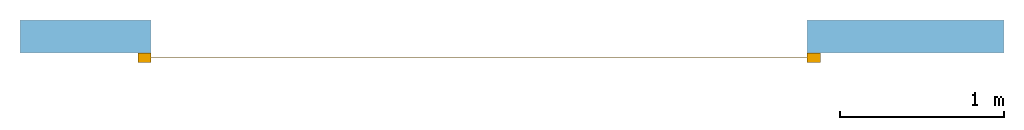
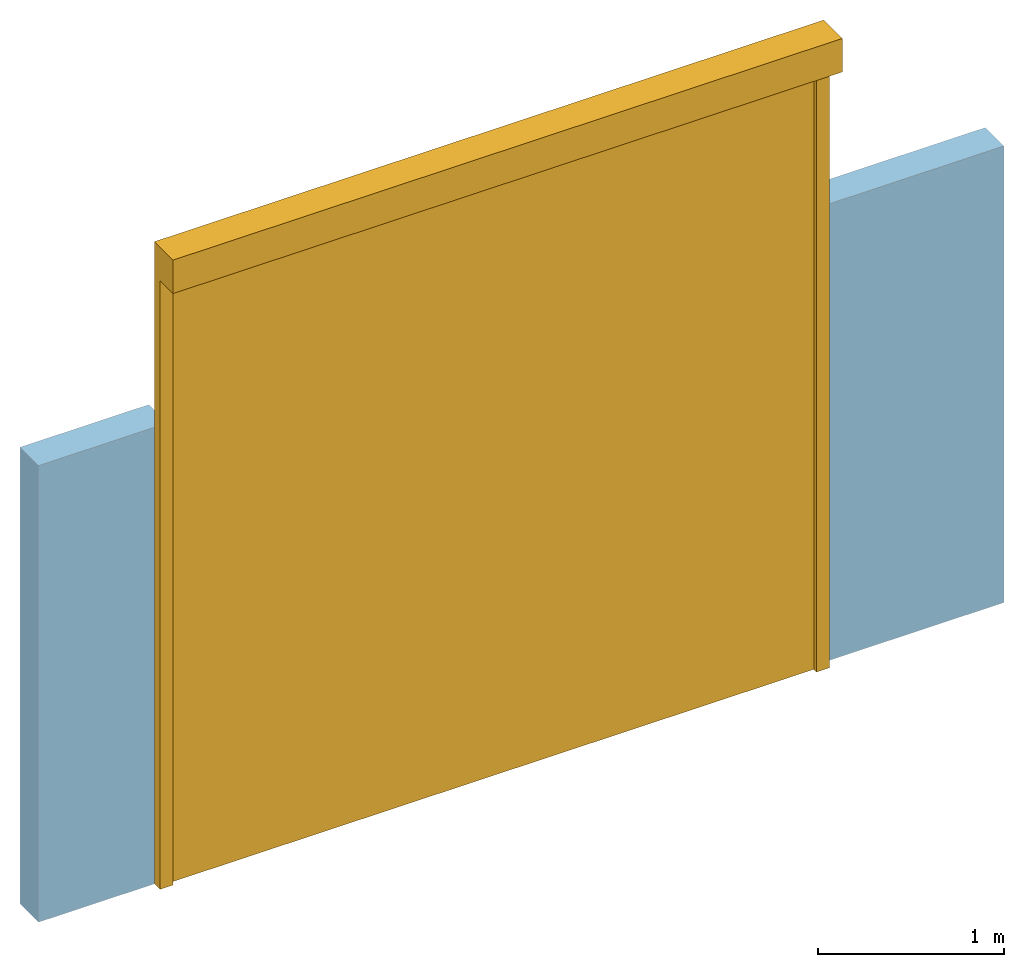
# One storey, part 2 of 2: 1 door, 1 opening, plus 1 element that does not belong to this part.
"""IFC2X3 building model written with IfcOpenShell, lengths in millimetres."""

from ifc_helpers import new_model, entity, si_unit, converted_unit, derived_unit, direction, frame, frame_2d, origin, place, context, subcontext, project, spatial, rectangle, extrude, faceted_brep, source, transform, mapped, material, material_list, layer, layer_set, layer_usage, type_object, type_shapes, element, fill, save


model = new_model("IFC2X3")

# Units and contexts
model_context = context("Model", 3, precision=0.01, world=origin(), true_north=direction((6.12303176911189e-17, 1.0)))
context_of_model = context(None, 3, precision=0.01, world=origin(), true_north=direction((6.12303176911189e-17, 1.0)))
body_context = subcontext(model_context, "Body", "Model", "MODEL_VIEW")
ifc_project = project(units=[si_unit("LENGTHUNIT", "METRE", prefix="MILLI"), si_unit("AREAUNIT", "SQUARE_METRE"), si_unit("VOLUMEUNIT", "CUBIC_METRE"), converted_unit("PLANEANGLEUNIT", "DEGREE", entity("IfcRatioMeasure", 0.0174532925199433), si_unit("PLANEANGLEUNIT", "RADIAN"), dimensions=[0, 0, 0, 0, 0, 0, 0]), si_unit("MASSUNIT", "GRAM", prefix="KILO"), si_unit("TIMEUNIT", "SECOND"), si_unit("FREQUENCYUNIT", "HERTZ"), si_unit("THERMODYNAMICTEMPERATUREUNIT", "DEGREE_CELSIUS"), derived_unit("THERMALTRANSMITTANCEUNIT", [(si_unit("MASSUNIT", "GRAM", prefix="KILO"), 1), (si_unit("THERMODYNAMICTEMPERATUREUNIT", "KELVIN"), -1), (si_unit("TIMEUNIT", "SECOND"), -3)]), derived_unit("VOLUMETRICFLOWRATEUNIT", [(si_unit("LENGTHUNIT", "METRE"), 3), (si_unit("TIMEUNIT", "SECOND"), -1)]), si_unit("ELECTRICCURRENTUNIT", "AMPERE"), si_unit("ELECTRICVOLTAGEUNIT", "VOLT"), si_unit("POWERUNIT", "WATT"), si_unit("FORCEUNIT", "NEWTON", prefix="KILO"), si_unit("ILLUMINANCEUNIT", "LUX"), si_unit("LUMINOUSFLUXUNIT", "LUMEN"), si_unit("LUMINOUSINTENSITYUNIT", "CANDELA"), si_unit("PRESSUREUNIT", "PASCAL")], contexts=[model_context, context_of_model])

# Site, building, storey
site_placement = place(None, origin())
site = spatial("IfcSite", under=ifc_project, at=site_placement, CompositionType="ELEMENT")
building_placement = place(site_placement, origin())
building = spatial("IfcBuilding", under=site, at=building_placement, CompositionType="ELEMENT")
storey_placement = place(building_placement, origin())
storey = spatial("IfcBuildingStorey", under=building, at=storey_placement, CompositionType="ELEMENT", Elevation=0.0)

# Wall, opening, door
ifc_material_1 = material()
ifc_layer = layer(ifc_material_1, 200.0)
ifc_layer_set = layer_set([ifc_layer])
ifc_layer_usage = layer_usage(ifc_layer_set, "AXIS2", "NEGATIVE", 100.0)
wall_type = type_object("IfcWallType", PredefinedType="STANDARD", material=ifc_layer_set)
wall_placement = place(storey_placement, frame((-30147.0958388037, 10047.082659008, 0.0)))
wall = element("IfcWallStandardCase", 1, at=wall_placement, inside=storey, type_object=wall_type, material=ifc_layer_usage, context=body_context, shape_type="SweptSolid", body=[
    extrude(rectangle(XDim=6000.0, YDim=199.999999999998, at=frame_2d((3000.0, 6.96331881044898e-13), x_axis=(-1.0, 0.0))), origin(), (0.0, 0.0, 1.0), 3000.0),
])
opening_placement = place(wall_placement, frame((565.0, -300.0, 0.0)))
opening = element("IfcOpeningElement", 2, at=opening_placement, cuts=wall, ObjectType="Opening", context=body_context, shape_type="Brep", body=[
    faceted_brep([(4235.0, 200.0, 4000.0), (4235.0, 400.0, 4000.0), (235.0, 400.0, 4000.0), (235.0, 200.0, 4000.0), (0.0, 200.0, 4000.0), (0.0, 0.0, 4000.0), (4420.0, 0.0, 4000.0), (4420.0, 200.0, 4000.0), (4235.0, 200.0, 0.0), (4420.0, 200.0, 0.0), (4420.0, 0.0, 0.0), (0.0, 0.0, 0.0), (0.0, 200.0, 0.0), (235.0, 200.0, 0.0), (235.0, 400.0, 0.0), (4235.0, 400.0, 0.0)], [[[0, 1, 2, 3, 4, 5, 6, 7]], [[8, 9, 10, 11, 12, 13, 14, 15]], [[1, 0, 8, 15]], [[2, 1, 15, 14]], [[3, 2, 14, 13]], [[4, 3, 13, 12]], [[5, 4, 12, 11]], [[6, 5, 11, 10]], [[7, 6, 10, 9]], [[0, 7, 9, 8]]]),
])
ifc_material_2 = material()
ifc_material_3 = material()
ifc_material_list_1 = material_list([ifc_material_2, ifc_material_3])
ifc_material_list_2 = material_list([ifc_material_2, ifc_material_3])
door_style = type_object("IfcDoorStyle", ConstructionType="NOTDEFINED", OperationType="NOTDEFINED", ParameterTakesPrecedence=False, Sizeable=False, material=ifc_material_list_2)
shared_shape = source(origin(), body_context, "Body", "Brep", [
    faceted_brep([(4185.0, 260.0, 0.0), (4265.0, 260.0, 0.0), (4265.0, 200.0, 0.0), (4185.0, 200.0, 0.0), (4185.0, 230.0, 0.0), (4195.0, 230.0, 0.0), (4195.0, 231.0, 0.0), (4185.0, 231.0, 0.0), (4185.0, 260.0, 4000.0), (4265.0, 260.0, 4000.0), (4265.0, 400.0, 4000.0), (4265.0, 400.0, 4220.0), (4265.0, 200.0, 4220.0), (105.0, 200.0, 4220.0), (105.0, 200.0, 0.0), (185.0, 200.0, 0.0), (185.0, 200.0, 4000.0), (4185.0, 200.0, 4000.0), (4185.0, 230.0, 4000.0), (4195.0, 230.0, 4000.0), (4195.0, 231.0, 4000.0), (4185.0, 231.0, 4000.0), (105.0, 400.0, 4220.0), (105.0, 400.0, 4000.0), (185.0, 230.0, 4000.0), (175.0, 230.0, 4000.0), (175.0, 231.0, 4000.0), (185.0, 231.0, 4000.0), (185.0, 260.0, 4000.0), (105.0, 260.0, 4000.0), (105.0, 260.0, 0.0), (185.0, 260.0, 0.0), (185.0, 231.0, 0.0), (175.0, 231.0, 0.0), (175.0, 230.0, 0.0), (185.0, 230.0, 0.0)], [[[0, 1, 2, 3, 4, 5, 6, 7]], [[1, 0, 8, 9]], [[2, 1, 9, 10, 11, 12]], [[3, 2, 12, 13, 14, 15, 16, 17]], [[4, 3, 17, 18]], [[5, 4, 18, 19]], [[6, 5, 19, 20]], [[7, 6, 20, 21]], [[0, 7, 21, 8]], [[11, 22, 13, 12]], [[23, 10, 9, 8, 21, 20, 19, 18, 17, 16, 24, 25, 26, 27, 28, 29]], [[22, 11, 10, 23]], [[14, 13, 22, 23, 29, 30]], [[31, 32, 33, 34, 35, 15, 14, 30]], [[31, 30, 29, 28]], [[15, 35, 24, 16]], [[35, 34, 25, 24]], [[34, 33, 26, 25]], [[33, 32, 27, 26]], [[32, 31, 28, 27]]]),
    faceted_brep([(4195.0, 231.0, 4000.0), (175.0, 231.0, 4000.0), (175.0, 230.0, 4000.0), (4195.0, 230.0, 4000.0), (4195.0, 231.0, 0.0), (4195.0, 230.0, 0.0), (175.0, 230.0, 0.0), (175.0, 231.0, 0.0)], [[[0, 1, 2, 3]], [[4, 5, 6, 7]], [[1, 0, 4, 7]], [[2, 1, 7, 6]], [[3, 2, 6, 5]], [[0, 3, 5, 4]]]),
])
type_shapes(door_style, [shared_shape])
door_placement = place(opening_placement, frame((4420.0, 400.0, 0.0), z_axis=(0.0, 0.0, 1.0), x_axis=(-1.0, 0.0, 0.0)))
door = element("IfcDoor", 3, at=door_placement, inside=storey, type_object=door_style, material=ifc_material_list_1, OverallHeight=4219.99999999998, OverallWidth=4160.00000000001, context=body_context, shape_type="MappedRepresentation", body=[
    mapped(shared_shape, transform((0.0, 0.0, 0.0), scale=1.0)),
])
fill(opening, door)

save(model, "model.ifc")
